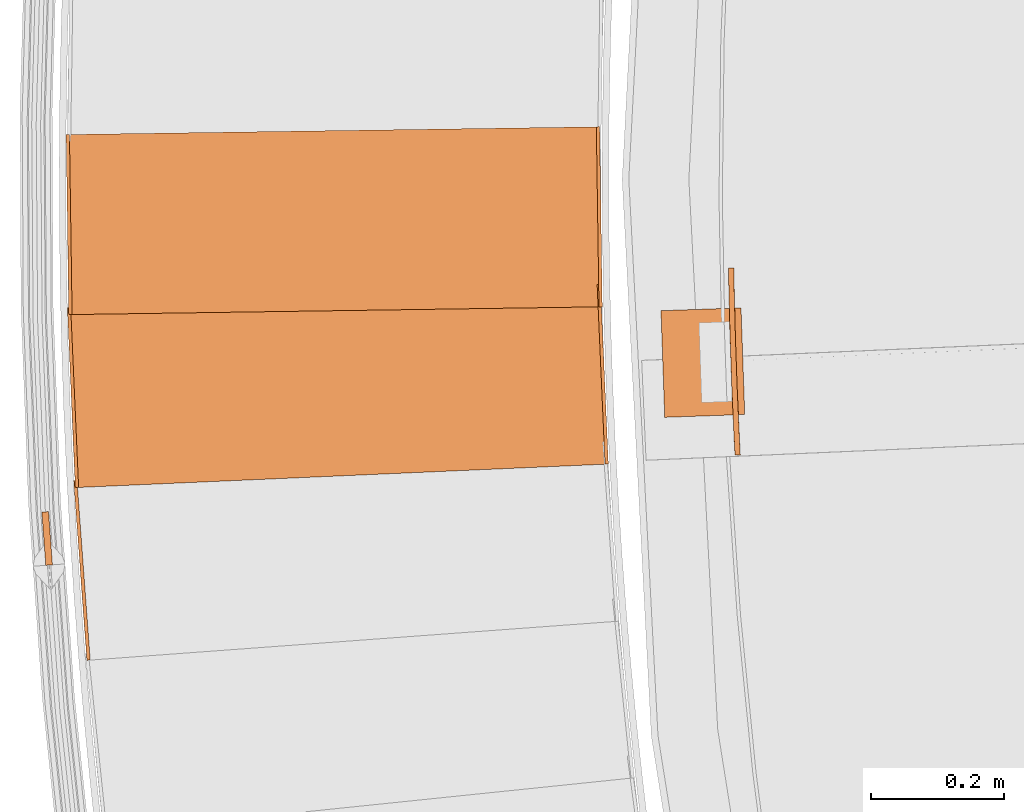
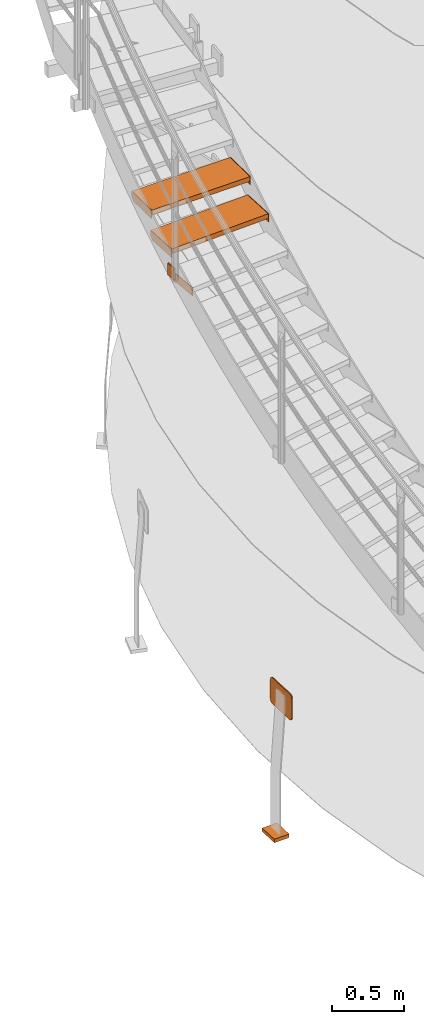
# One storey, part 53 of 126: 10 proxies.
"""IFC2X3 building model written with IfcOpenShell, lengths in millimetres."""

from ifc_helpers import new_model, si_unit, origin, origin_with_axes, place, context, project, spatial, faceted_brep, material, element, save


model = new_model("IFC2X3")

# Units and contexts
context_of_model_1 = context(None, 3, precision=0.1, world=origin())
context_of_model_2 = context(None, 3, precision=0.1, world=origin())
ifc_project = project(units=[si_unit("LENGTHUNIT", "METRE", prefix="MILLI"), si_unit("AREAUNIT", "SQUARE_METRE", prefix="CENTI"), si_unit("VOLUMEUNIT", "CUBIC_METRE", prefix="CENTI"), si_unit("MASSUNIT", "GRAM", prefix="KILO")], contexts=[context_of_model_1, context_of_model_2])

# Site, building, storey
site_placement = place(None, origin_with_axes())
site = spatial("IfcSite", under=ifc_project, at=site_placement, CompositionType="ELEMENT")
building_placement = place(site_placement, origin_with_axes())
building = spatial("IfcBuilding", under=site, at=building_placement, CompositionType="ELEMENT")
storey_placement = place(building_placement, origin_with_axes())
storey = spatial("IfcBuildingStorey", under=building, at=storey_placement, CompositionType="ELEMENT")

# Proxies
ifc_material_1 = material(Name="S235JRG2")
proxy_1_placement = place(storey_placement, origin_with_axes())
element("IfcBuildingElementProxy", 1, at=proxy_1_placement, inside=storey, material=ifc_material_1, context=context_of_model_2, shape_type="Brep", body=[
    faceted_brep([(-782.4544, 7283.9728, 4606.11), (-777.4679, 7284.3402, 4606.11), (-777.4679, 7284.3402, 4676.11), (-782.4544, 7283.9728, 4676.11), (-802.2917, 7553.2431, 4676.11), (-797.3052, 7553.6105, 4676.11), (-797.3052, 7553.6105, 4636.11), (-802.2917, 7553.2431, 4636.11), (-800.0876, 7523.3242, 4606.11), (-795.1011, 7523.6915, 4606.11)], [[[0, 1, 2, 3]], [[4, 5, 6, 7]], [[0, 8, 9, 1]], [[1, 9, 6, 5, 2]], [[2, 5, 4, 3]], [[0, 3, 4, 7, 8]], [[6, 9, 8, 7]]]),
])
proxy_2_placement = place(storey_placement, origin_with_axes())
element("IfcBuildingElementProxy", 2, at=proxy_2_placement, inside=storey, material=ifc_material_1, context=context_of_model_2, shape_type="Brep", body=[
    faceted_brep([(-794.8744, 7543.1514, 4809.27), (-794.8744, 7543.1514, 4849.27), (-806.7775, 7812.8888, 4849.27), (-806.7775, 7812.8888, 4809.27), (-5.6424, 7577.9792, 4809.27), (-17.5456, 7847.7167, 4809.27), (-17.5456, 7847.7167, 4849.27), (-5.6424, 7577.9792, 4849.27)], [[[0, 1, 2, 3]], [[4, 5, 6, 7]], [[0, 4, 7, 1]], [[1, 7, 6, 2]], [[2, 6, 5, 3]], [[3, 5, 4, 0]]]),
])
proxy_3_placement = place(storey_placement, origin_with_axes())
element("IfcBuildingElementProxy", 3, at=proxy_3_placement, inside=storey, material=ifc_material_1, context=context_of_model_2, shape_type="Brep", body=[
    faceted_brep([(-5.6424, 7577.9792, 4779.27), (-0.6473, 7578.1996, 4779.27), (-0.6473, 7578.1996, 4849.27), (-5.6424, 7577.9792, 4849.27), (-17.5456, 7847.7167, 4849.27), (-12.5505, 7847.9371, 4849.27), (-12.5505, 7847.9371, 4809.27), (-17.5456, 7847.7167, 4809.27), (-16.223, 7817.7458, 4779.27), (-11.2279, 7817.9663, 4779.27)], [[[0, 1, 2, 3]], [[4, 5, 6, 7]], [[0, 8, 9, 1]], [[1, 9, 6, 5, 2]], [[2, 5, 4, 3]], [[0, 3, 4, 7, 8]], [[6, 9, 8, 7]]]),
])
proxy_4_placement = place(storey_placement, origin_with_axes())
element("IfcBuildingElementProxy", 4, at=proxy_4_placement, inside=storey, material=ifc_material_1, context=context_of_model_2, shape_type="Brep", body=[
    faceted_brep([(-799.8695, 7542.9309, 4779.27), (-794.8744, 7543.1514, 4779.27), (-794.8744, 7543.1514, 4849.27), (-799.8695, 7542.9309, 4849.27), (-811.7727, 7812.6684, 4849.27), (-806.7775, 7812.8888, 4849.27), (-806.7775, 7812.8888, 4809.27), (-811.7727, 7812.6684, 4809.27), (-810.4501, 7782.6976, 4779.27), (-805.455, 7782.918, 4779.27)], [[[0, 1, 2, 3]], [[4, 5, 6, 7]], [[0, 8, 9, 1]], [[1, 9, 6, 5, 2]], [[2, 5, 4, 3]], [[0, 3, 4, 7, 8]], [[6, 9, 8, 7]]]),
])
proxy_5_placement = place(storey_placement, origin_with_axes())
element("IfcBuildingElementProxy", 5, at=proxy_5_placement, inside=storey, material=ifc_material_1, context=context_of_model_2, shape_type="Brep", body=[
    faceted_brep([(-804.6556, 7802.3627, 4982.43), (-804.6556, 7802.3627, 5022.43), (-808.6143, 8072.3337, 5022.43), (-808.6143, 8072.3337, 4982.43), (-14.7405, 7813.9456, 4982.43), (-18.6992, 8083.9166, 4982.43), (-18.6992, 8083.9166, 5022.43), (-14.7405, 7813.9456, 5022.43)], [[[0, 1, 2, 3]], [[4, 5, 6, 7]], [[0, 4, 7, 1]], [[1, 7, 6, 2]], [[2, 6, 5, 3]], [[3, 5, 4, 0]]]),
])
proxy_6_placement = place(storey_placement, origin_with_axes())
element("IfcBuildingElementProxy", 6, at=proxy_6_placement, inside=storey, material=ifc_material_1, context=context_of_model_2, shape_type="Brep", body=[
    faceted_brep([(-14.7405, 7813.9456, 4952.43), (-9.741, 7814.0189, 4952.43), (-9.741, 7814.0189, 5022.43), (-14.7405, 7813.9456, 5022.43), (-18.6992, 8083.9166, 5022.43), (-13.6997, 8083.9899, 5022.43), (-13.6997, 8083.9899, 4982.43), (-18.6992, 8083.9166, 4982.43), (-18.2593, 8053.9198, 4952.43), (-13.2599, 8053.9931, 4952.43)], [[[0, 1, 2, 3]], [[4, 5, 6, 7]], [[0, 8, 9, 1]], [[1, 9, 6, 5, 2]], [[2, 5, 4, 3]], [[0, 3, 4, 7, 8]], [[6, 9, 8, 7]]]),
])
proxy_7_placement = place(storey_placement, origin_with_axes())
element("IfcBuildingElementProxy", 7, at=proxy_7_placement, inside=storey, material=ifc_material_1, context=context_of_model_2, shape_type="Brep", body=[
    faceted_brep([(-809.655, 7802.2894, 4952.43), (-804.6556, 7802.3627, 4952.43), (-804.6556, 7802.3627, 5022.43), (-809.655, 7802.2894, 5022.43), (-813.6137, 8072.2604, 5022.43), (-808.6143, 8072.3337, 5022.43), (-808.6143, 8072.3337, 4982.43), (-813.6137, 8072.2604, 4982.43), (-813.1739, 8042.2636, 4952.43), (-808.1744, 8042.3369, 4952.43)], [[[0, 1, 2, 3]], [[4, 5, 6, 7]], [[0, 8, 9, 1]], [[1, 9, 6, 5, 2]], [[2, 5, 4, 3]], [[0, 3, 4, 7, 8]], [[6, 9, 8, 7]]]),
])
ifc_material_2 = material(Name="STAHL")
proxy_8_placement = place(storey_placement, origin_with_axes())
element("IfcBuildingElementProxy", 8, at=proxy_8_placement, inside=storey, material=ifc_material_2, Name="profile", context=context_of_model_2, shape_type="Brep", body=[
    faceted_brep([(187.6, 7859.1, 704.8), (187.5, 7863.4, 701.2), (179.5, 7863.2, 701.2), (179.6, 7858.5, 705.0), (187.7, 7854.1, 707.5), (179.7, 7853.0, 707.9), (187.8, 7848.1, 709.4), (179.8, 7847.5, 709.5), (187.9, 7615.8, 709.4), (195.9, 7616.6, 709.5), (195.6, 7622.2, 710.0), (192.3, 7695.5, 710.0), (189.8, 7768.8, 710.0), (187.9, 7842.1, 710.0), (179.9, 7842.0, 710.0), (181.8, 7768.6, 710.0), (184.3, 7695.1, 710.0), (187.6, 7621.7, 710.0), (196.8, 7597.4, 696.9), (196.7, 7601.0, 701.2), (188.7, 7600.6, 701.2), (188.9, 7596.8, 696.5), (197.0, 7594.7, 691.9), (189.0, 7593.9, 691.0), (197.1, 7592.8, 686.0), (189.1, 7592.3, 685.5), (189.1, 7591.8, 680.0), (189.1, 7591.8, 520.0), (189.1, 7592.4, 514.0), (197.1, 7592.7, 514.5), (197.1, 7592.2, 520.0), (197.1, 7592.2, 680.0), (179.6, 7858.9, 495.2), (179.5, 7863.2, 498.8), (187.5, 7863.4, 498.8), (187.6, 7858.7, 495.0), (179.7, 7853.9, 492.5), (187.7, 7853.2, 492.1), (179.8, 7848.0, 490.6), (187.8, 7847.7, 490.5), (187.9, 7616.2, 490.5), (187.6, 7621.7, 490.0), (184.3, 7695.1, 490.0), (181.8, 7768.6, 490.0), (179.9, 7842.0, 490.0), (187.9, 7842.1, 490.0), (189.8, 7768.8, 490.0), (192.3, 7695.5, 490.0), (195.6, 7622.2, 490.0), (195.9, 7616.2, 490.6), (188.9, 7597.0, 503.1), (188.7, 7600.6, 498.8), (196.7, 7601.0, 498.8), (196.9, 7597.2, 503.5), (189.0, 7594.3, 508.1), (197.0, 7594.3, 509.0), (188.1, 7610.7, 492.1), (196.2, 7610.3, 492.5), (188.4, 7605.2, 495.0), (196.4, 7605.3, 495.2), (179.4, 7871.4, 686.0), (187.3, 7871.6, 685.5), (187.3, 7872.1, 680.0), (187.3, 7872.1, 520.0), (187.3, 7871.5, 514.0), (179.3, 7871.5, 514.5), (179.3, 7872.0, 520.0), (179.3, 7872.0, 680.0), (179.4, 7869.9, 509.0), (187.4, 7869.7, 508.1), (179.4, 7867.0, 503.5), (187.4, 7866.9, 503.1), (196.1, 7611.1, 707.9), (188.2, 7609.8, 707.5), (196.4, 7605.6, 705.0), (188.4, 7604.8, 704.8), (187.4, 7870.0, 691.0), (179.4, 7869.5, 691.9), (187.4, 7867.2, 696.5), (179.4, 7866.8, 696.9)], [[[0, 1, 2, 3]], [[4, 0, 3, 5]], [[6, 4, 5, 7]], [[8, 9, 10, 11, 12, 13, 6, 7, 14, 15, 16, 17]], [[18, 19, 20, 21]], [[22, 18, 21, 23]], [[24, 22, 23, 25]], [[26, 27, 28, 29, 30, 31, 24, 25]], [[32, 33, 34, 35]], [[36, 32, 35, 37]], [[38, 36, 37, 39]], [[40, 41, 42, 43, 44, 38, 39, 45, 46, 47, 48, 49]], [[50, 51, 52, 53]], [[54, 50, 53, 55]], [[28, 54, 55, 29]], [[56, 40, 49, 57]], [[58, 56, 57, 59]], [[51, 58, 59, 52]], [[60, 61, 62, 63, 64, 65, 66, 67]], [[68, 65, 64, 69]], [[70, 68, 69, 71]], [[33, 70, 71, 34]], [[72, 9, 8, 73]], [[74, 72, 73, 75]], [[19, 74, 75, 20]], [[76, 61, 60, 77]], [[78, 76, 77, 79]], [[1, 78, 79, 2]], [[31, 30, 29, 55, 53, 52, 59, 57, 49, 48, 47, 46, 45, 39, 37, 35, 34, 71, 69, 64, 63, 62, 61, 76, 78, 1, 0, 4, 6, 13, 12, 11, 10, 9, 72, 74, 19, 18, 22, 24]], [[27, 26, 25, 23, 21, 20, 75, 73, 8, 17, 16, 15, 14, 7, 5, 3, 2, 79, 77, 60, 67, 66, 65, 68, 70, 33, 32, 36, 38, 44, 43, 42, 41, 40, 56, 58, 51, 50, 54, 28]]]),
])
proxy_9_placement = place(storey_placement, origin_with_axes())
element("IfcBuildingElementProxy", 9, at=proxy_9_placement, inside=storey, material=ifc_material_2, Name="profile", context=context_of_model_2, shape_type="Brep", body=[
    faceted_brep([(203.8, 7652.5, -530.0), (83.8, 7648.3, -530.0), (78.2, 7808.2, -530.0), (198.2, 7812.4, -530.0), (83.8, 7648.3, -500.0), (78.2, 7808.2, -500.0), (203.8, 7652.5, -500.0), (198.2, 7812.4, -500.0)], [[[0, 1, 2, 3]], [[1, 4, 5, 2]], [[4, 6, 7, 5]], [[6, 0, 3, 7]], [[1, 0, 6, 4]], [[7, 3, 2, 5]]]),
])
proxy_10_placement = place(storey_placement, origin_with_axes())
element("IfcBuildingElementProxy", 10, at=proxy_10_placement, inside=storey, material=ifc_material_1, Name="HANDLAUF", context=context_of_model_2, shape_type="Brep", body=[
    faceted_brep([(-849.9452, 7506.2159, 4673.4208), (-839.9717, 7506.9429, 4673.4208), (-834.1559, 7427.1546, 4673.4208), (-844.1295, 7426.4276, 4673.4208), (-849.9452, 7506.2159, 4773.4208), (-844.1295, 7426.4276, 4773.4208), (-834.1559, 7427.1546, 4773.4208), (-839.9717, 7506.9429, 4773.4208)], [[[0, 1, 2, 3]], [[4, 5, 6, 7]], [[0, 4, 7, 1]], [[1, 7, 6, 2]], [[2, 6, 5, 3]], [[3, 5, 4, 0]]]),
])

save(model, "model.ifc")
